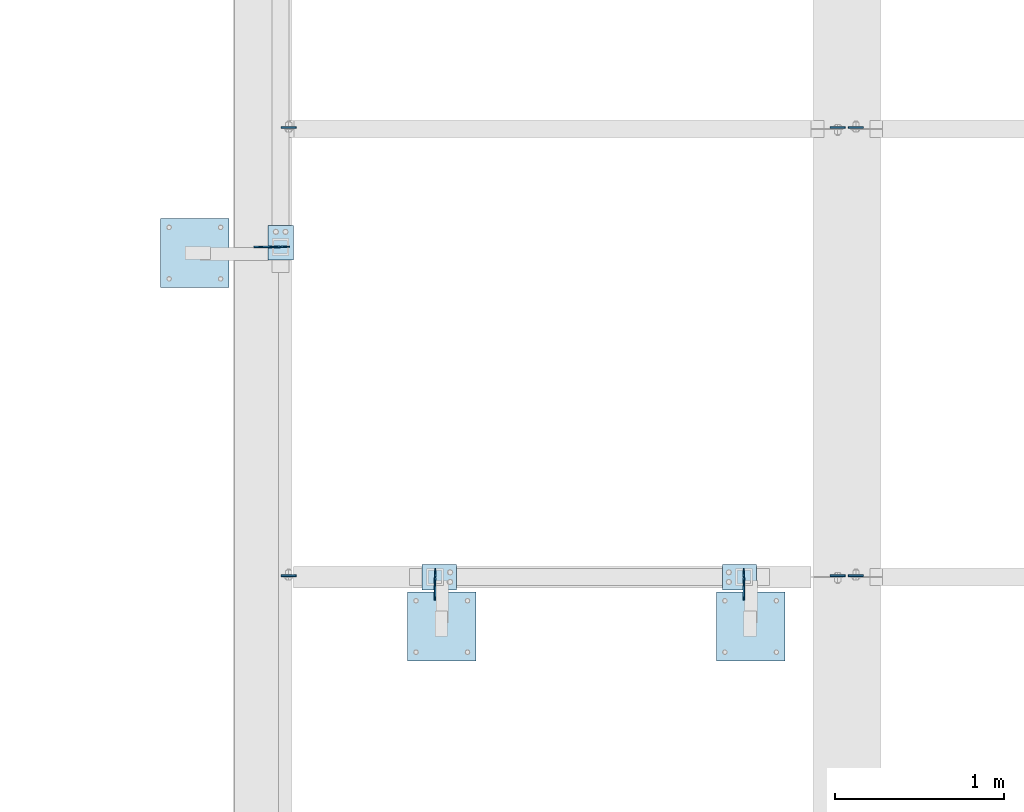
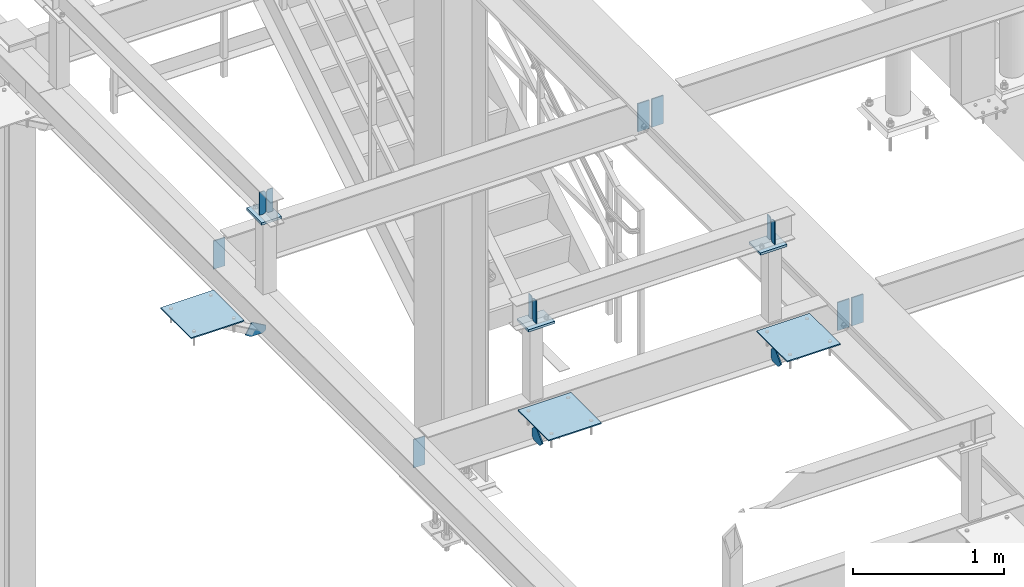
# One storey, part 3015 of 3843: 21 plates, 13 elements without a shape of their own.
"""IFC2X3 building model written with IfcOpenShell, lengths in millimetres."""

from ifc_helpers import new_model, si_unit, frame, origin_with_axes, place, context, subcontext, project, spatial, faceted_brep, material, type_object, element, aggregate, save


model = new_model("IFC2X3")

# Units and contexts
model_context = context("Model", 3, precision=1e-05, world=origin_with_axes())
body_context = subcontext(model_context, "Body", "Model", "MODEL_VIEW")
ifc_project = project(units=[si_unit("LENGTHUNIT", "METRE", prefix="MILLI"), si_unit("AREAUNIT", "SQUARE_METRE"), si_unit("VOLUMEUNIT", "CUBIC_METRE"), si_unit("MASSUNIT", "GRAM", prefix="KILO"), si_unit("TIMEUNIT", "SECOND"), si_unit("PLANEANGLEUNIT", "RADIAN"), si_unit("SOLIDANGLEUNIT", "STERADIAN"), si_unit("THERMODYNAMICTEMPERATUREUNIT", "DEGREE_CELSIUS"), si_unit("LUMINOUSINTENSITYUNIT", "LUMEN")], contexts=[model_context])

# Site, building, storey
site_placement = place(None, origin_with_axes())
site = spatial("IfcSite", under=ifc_project, at=site_placement, CompositionType="ELEMENT")
building_placement = place(site_placement, origin_with_axes())
building = spatial("IfcBuilding", under=site, at=building_placement, Name="Undefined", CompositionType="ELEMENT")
storey_placement = place(building_placement, origin_with_axes())
storey = spatial("IfcBuildingStorey", under=building, at=storey_placement, Name="Undefined", CompositionType="ELEMENT", Elevation=0.0)

# Assembly, plates
assembly_1_placement = place(storey_placement, origin_with_axes())
assembly_1 = element("IfcElementAssembly", 1, at=assembly_1_placement, inside=storey, Name="BEAM", AssemblyPlace="NOTDEFINED", PredefinedType="RIGID_FRAME")
ifc_material = material(Name="STEEL/A572-50")
plate_type_1 = type_object("IfcPlateType", PredefinedType="NOTDEFINED")
plate_1_placement = place(assembly_1_placement, frame((36585.525, 20315.2375, 34747.2), z_axis=(1.0, 0.0, 0.0), x_axis=(0.0, 0.0, -1.0)))
plate_1 = element("IfcPlate", 2, at=plate_1_placement, type_object=plate_type_1, material=ifc_material, Name="PLATE", context=body_context, shape_type="Brep", body=[
    faceted_brep([(0.0, -4.76249999999709, 0.0), (0.0, -4.76249999999709, 88.9000015258789), (0.0, 4.76249999999709, 88.9000015258789), (0.0, 4.76249999999709, 0.0), (228.600006102781, -4.7625000004191, 88.9000015257589), (228.600006102781, 4.76249999954598, 88.9000015257443), (228.600006103079, -4.7625000004482, 7.27595761418343e-12), (228.600006103079, 4.76249999954598, -7.27595761418343e-12)], [[[0, 1, 2, 3]], [[1, 4, 5, 2]], [[4, 6, 7, 5]], [[6, 0, 3, 7]], [[5, 7, 3, 2]], [[6, 4, 1, 0]]]),
])
plate_2_placement = place(assembly_1_placement, frame((36566.475, 20315.2375, 34747.2), z_axis=(-1.0, 0.0, 0.0), x_axis=(0.0, 0.0, -1.0)))
plate_2 = element("IfcPlate", 3, at=plate_2_placement, type_object=plate_type_1, material=ifc_material, Name="PLATE", context=body_context, shape_type="Brep", body=[
    faceted_brep([(0.0, -4.76249999999709, 0.0), (0.0, -4.76249999999709, 88.9000015258789), (0.0, 4.76249999999709, 88.9000015258789), (0.0, 4.76249999999709, 0.0), (228.600006102781, -4.7625000004191, 88.9000015257589), (228.600006102781, 4.76249999954598, 88.9000015257443), (228.600006103079, -4.7625000004482, 7.27595761418343e-12), (228.600006103079, 4.76249999954598, -7.27595761418343e-12)], [[[0, 1, 2, 3]], [[1, 4, 5, 2]], [[4, 6, 7, 5]], [[6, 0, 3, 7]], [[5, 7, 3, 2]], [[6, 4, 1, 0]]]),
])

# Assembly, plate
assembly_2_placement = place(storey_placement, origin_with_axes())
assembly_2 = element("IfcElementAssembly", 4, at=assembly_2_placement, inside=storey, Name="BEAM", AssemblyPlace="NOTDEFINED", PredefinedType="RIGID_FRAME")
plate_3_placement = place(assembly_2_placement, frame((33226.375, 20315.2375, 34772.6), z_axis=(1.0, 0.0, 0.0), x_axis=(0.0, 0.0, -1.0)))
plate_3 = element("IfcPlate", 5, at=plate_3_placement, type_object=plate_type_1, material=ifc_material, Name="PLATE", context=body_context, shape_type="Brep", body=[
    faceted_brep([(0.0, -4.76249999999709, 0.0), (0.0, -4.76249999999709, 88.9000015258789), (0.0, 4.76249999999709, 88.9000015258789), (0.0, 4.76249999999709, 0.0), (228.600006102781, -4.7625000004191, 88.9000015257589), (228.600006102781, 4.76249999954598, 88.9000015257443), (228.600006103079, -4.7625000004482, 7.27595761418343e-12), (228.600006103079, 4.76249999954598, -7.27595761418343e-12)], [[[0, 1, 2, 3]], [[1, 4, 5, 2]], [[4, 6, 7, 5]], [[6, 0, 3, 7]], [[5, 7, 3, 2]], [[6, 4, 1, 0]]]),
])

# Plate
plate_4_placement = place(assembly_1_placement, frame((36585.525, 22969.5375, 34747.2), z_axis=(1.0, 0.0, 0.0), x_axis=(0.0, 0.0, -1.0)))
plate_4 = element("IfcPlate", 6, at=plate_4_placement, type_object=plate_type_1, material=ifc_material, Name="PLATE", context=body_context, shape_type="Brep", body=[
    faceted_brep([(0.0, -4.76249999999709, 0.0), (0.0, -4.76249999999709, 88.9000015258789), (0.0, 4.76249999999709, 88.9000015258789), (0.0, 4.76249999999709, 0.0), (228.600006102781, -4.7625000004191, 88.9000015257589), (228.600006102781, 4.76249999954598, 88.9000015257443), (228.600006103079, -4.7625000004482, 7.27595761418343e-12), (228.600006103079, 4.76249999954598, -7.27595761418343e-12)], [[[0, 1, 2, 3]], [[1, 4, 5, 2]], [[4, 6, 7, 5]], [[6, 0, 3, 7]], [[5, 7, 3, 2]], [[6, 4, 1, 0]]]),
])

plate_5_placement = place(assembly_1_placement, frame((36566.475, 22969.5375, 34747.2), z_axis=(-1.0, 0.0, 0.0), x_axis=(0.0, 0.0, -1.0)))
plate_5 = element("IfcPlate", 7, at=plate_5_placement, type_object=plate_type_1, material=ifc_material, Name="PLATE", context=body_context, shape_type="Brep", body=[
    faceted_brep([(0.0, -4.76249999999709, 0.0), (0.0, -4.76249999999709, 88.9000015258789), (0.0, 4.76249999999709, 88.9000015258789), (0.0, 4.76249999999709, 0.0), (228.600006102781, -4.7625000004191, 88.9000015257589), (228.600006102781, 4.76249999954598, 88.9000015257443), (228.600006103079, -4.7625000004482, 7.27595761418343e-12), (228.600006103079, 4.76249999954598, -7.27595761418343e-12)], [[[0, 1, 2, 3]], [[1, 4, 5, 2]], [[4, 6, 7, 5]], [[6, 0, 3, 7]], [[5, 7, 3, 2]], [[6, 4, 1, 0]]]),
])

aggregate(assembly_1, [plate_1, plate_2, plate_4, plate_5])

plate_6_placement = place(assembly_2_placement, frame((33226.375, 22969.5375, 34772.6), z_axis=(1.0, 0.0, 0.0), x_axis=(0.0, 0.0, -1.0)))
plate_6 = element("IfcPlate", 8, at=plate_6_placement, type_object=plate_type_1, material=ifc_material, Name="PLATE", context=body_context, shape_type="Brep", body=[
    faceted_brep([(0.0, -4.76249999999709, 0.0), (0.0, -4.76249999999709, 88.9000015258789), (0.0, 4.76249999999709, 88.9000015258789), (0.0, 4.76249999999709, 0.0), (228.600006102781, -4.7625000004191, 88.9000015257589), (228.600006102781, 4.76249999954598, 88.9000015257443), (228.600006103079, -4.7625000004482, 7.27595761418343e-12), (228.600006103079, 4.76249999954598, -7.27595761418343e-12)], [[[0, 1, 2, 3]], [[1, 4, 5, 2]], [[4, 6, 7, 5]], [[6, 0, 3, 7]], [[5, 7, 3, 2]], [[6, 4, 1, 0]]]),
])

aggregate(assembly_2, [plate_3, plate_6])

# Assembly, plate
assembly_3_placement = place(storey_placement, origin_with_axes())
assembly_3 = element("IfcElementAssembly", 9, at=assembly_3_placement, inside=storey, Name="PLATE", AssemblyPlace="NOTDEFINED", PredefinedType="RIGID_FRAME")
plate_type_2 = type_object("IfcPlateType", PredefinedType="NOTDEFINED")
plate_7_placement = place(assembly_3_placement, frame((33220.0250000001, 22263.1, 34469.3875000009), z_axis=(-1.0, 0.0, 0.0), x_axis=(0.0, 0.0, 1.0)))
plate_7 = element("IfcPlate", 10, at=plate_7_placement, type_object=plate_type_2, material=ifc_material, Name="PLATE", context=body_context, shape_type="Brep", body=[
    faceted_brep([(0.0, -4.76249999999709, 19.0499992370605), (0.0, -4.76250000000073, 112.1731560966), (0.0, 4.76250000000073, 112.1731560966), (0.0, 4.76249999999709, 19.0499992370605), (25.4000000553569, -4.76250000000073, 156.167246576886), (25.4000000553569, 4.76250000000073, 156.167246576886), (113.388181015936, -4.76250000000073, 105.367246466165), (113.388181015936, 4.76250000000073, 105.367246466165), (52.5543727281402, -4.76250000000073, 0.0), (52.5543727281402, 4.76250000000073, 0.0), (19.0499992370605, -4.76249999999709, 0.0), (19.0499992370605, 4.76249999999709, 0.0)], [[[0, 1, 2, 3]], [[1, 4, 5, 2]], [[4, 6, 7, 5]], [[6, 8, 9, 7]], [[8, 10, 11, 9]], [[10, 0, 3, 11]], [[5, 7, 9, 11, 3, 2]], [[10, 8, 6, 4, 1, 0]]]),
])
aggregate(assembly_3, [plate_7])

# Assembly, plates
assembly_4_placement = place(storey_placement, origin_with_axes())
assembly_4 = element("IfcElementAssembly", 11, at=assembly_4_placement, inside=storey, Name="BEAM", AssemblyPlace="NOTDEFINED", PredefinedType="RIGID_FRAME")
plate_type_3 = type_object("IfcPlateType", PredefinedType="NOTDEFINED")
plate_8_placement = place(assembly_4_placement, frame((34137.6, 20256.5, 35615.5624969482), z_axis=(0.0, 0.0, -1.0), x_axis=(0.0, 1.0, 0.0)))
plate_8 = element("IfcPlate", 12, at=plate_8_placement, type_object=plate_type_3, material=ifc_material, Name="STIFFENER", context=body_context, shape_type="Brep", body=[
    faceted_brep([(0.0, -3.17499999999927, 0.0), (0.0, -3.17500000000291, 187.324999999997), (0.0, 3.17500000000291, 187.324999999997), (0.0, 3.17499999999927, 0.0), (34.9250001907349, -3.17500000000291, 187.324999999997), (34.9250001907349, 3.17500000000291, 187.324999999997), (47.625, -3.17500000000291, 174.625000190732), (47.625, 3.17500000000291, 174.625000190732), (47.625, -3.17499999999927, 12.6999998092651), (47.625, 3.17499999999927, 12.6999998092651), (34.9250001907349, -3.17499999999927, 0.0), (34.9250001907349, 3.17499999999927, 0.0)], [[[0, 1, 2, 3]], [[1, 4, 5, 2]], [[4, 6, 7, 5]], [[6, 8, 9, 7]], [[8, 10, 11, 9]], [[10, 0, 3, 11]], [[5, 7, 9, 11, 3, 2]], [[10, 8, 6, 4, 1, 0]]]),
])
plate_9_placement = place(assembly_4_placement, frame((34137.6, 20358.1, 35615.5624969482), z_axis=(0.0, 0.0, -1.0), x_axis=(0.0, -1.0, 0.0)))
plate_9 = element("IfcPlate", 13, at=plate_9_placement, type_object=plate_type_3, material=ifc_material, Name="STIFFENER", context=body_context, shape_type="Brep", body=[
    faceted_brep([(0.0, -3.17499999999927, 0.0), (0.0, -3.17500000000291, 187.324999999997), (0.0, 3.17500000000291, 187.324999999997), (0.0, 3.17499999999927, 0.0), (34.9250001907349, -3.17500000000291, 187.324999999997), (34.9250001907349, 3.17500000000291, 187.324999999997), (47.625, -3.17500000000291, 174.625000190732), (47.625, 3.17500000000291, 174.625000190732), (47.625, -3.17499999999927, 12.6999998092651), (47.625, 3.17499999999927, 12.6999998092651), (34.9250001907349, -3.17499999999927, 0.0), (34.9250001907349, 3.17499999999927, 0.0)], [[[0, 1, 2, 3]], [[1, 4, 5, 2]], [[4, 6, 7, 5]], [[6, 8, 9, 7]], [[8, 10, 11, 9]], [[10, 0, 3, 11]], [[5, 7, 9, 11, 3, 2]], [[10, 8, 6, 4, 1, 0]]]),
])
plate_10_placement = place(assembly_4_placement, frame((35966.4, 20358.1, 35615.5624969482), z_axis=(0.0, 0.0, -1.0), x_axis=(0.0, -1.0, 0.0)))
plate_10 = element("IfcPlate", 14, at=plate_10_placement, type_object=plate_type_3, material=ifc_material, Name="STIFFENER", context=body_context, shape_type="Brep", body=[
    faceted_brep([(0.0, -3.17499999999927, 0.0), (0.0, -3.17500000000291, 187.324999999997), (0.0, 3.17500000000291, 187.324999999997), (0.0, 3.17499999999927, 0.0), (34.9250001907349, -3.17500000000291, 187.324999999997), (34.9250001907349, 3.17500000000291, 187.324999999997), (47.625, -3.17500000000291, 174.625000190732), (47.625, 3.17500000000291, 174.625000190732), (47.625, -3.17499999999927, 12.6999998092651), (47.625, 3.17499999999927, 12.6999998092651), (34.9250001907349, -3.17499999999927, 0.0), (34.9250001907349, 3.17499999999927, 0.0)], [[[0, 1, 2, 3]], [[1, 4, 5, 2]], [[4, 6, 7, 5]], [[6, 8, 9, 7]], [[8, 10, 11, 9]], [[10, 0, 3, 11]], [[5, 7, 9, 11, 3, 2]], [[10, 8, 6, 4, 1, 0]]]),
])
plate_11_placement = place(assembly_4_placement, frame((35966.4, 20256.5, 35615.5624969482), z_axis=(0.0, 0.0, -1.0), x_axis=(0.0, 1.0, 0.0)))
plate_11 = element("IfcPlate", 15, at=plate_11_placement, type_object=plate_type_3, material=ifc_material, Name="STIFFENER", context=body_context, shape_type="Brep", body=[
    faceted_brep([(0.0, -3.17499999999927, 0.0), (0.0, -3.17500000000291, 187.324999999997), (0.0, 3.17500000000291, 187.324999999997), (0.0, 3.17499999999927, 0.0), (34.9250001907349, -3.17500000000291, 187.324999999997), (34.9250001907349, 3.17500000000291, 187.324999999997), (47.625, -3.17500000000291, 174.625000190732), (47.625, 3.17500000000291, 174.625000190732), (47.625, -3.17499999999927, 12.6999998092651), (47.625, 3.17499999999927, 12.6999998092651), (34.9250001907349, -3.17499999999927, 0.0), (34.9250001907349, 3.17499999999927, 0.0)], [[[0, 1, 2, 3]], [[1, 4, 5, 2]], [[4, 6, 7, 5]], [[6, 8, 9, 7]], [[8, 10, 11, 9]], [[10, 0, 3, 11]], [[5, 7, 9, 11, 3, 2]], [[10, 8, 6, 4, 1, 0]]]),
])
aggregate(assembly_4, [plate_8, plate_9, plate_10, plate_11])

assembly_5_placement = place(storey_placement, origin_with_axes())
assembly_5 = element("IfcElementAssembly", 16, at=assembly_5_placement, inside=storey, Name="BEAM", AssemblyPlace="NOTDEFINED", PredefinedType="RIGID_FRAME")
plate_12_placement = place(assembly_5_placement, frame((33274.0, 22263.1, 35615.5624969482), z_axis=(0.0, 0.0, -1.0), x_axis=(-1.0, 0.0, 0.0)))
plate_12 = element("IfcPlate", 17, at=plate_12_placement, type_object=plate_type_3, material=ifc_material, Name="STIFFENER", context=body_context, shape_type="Brep", body=[
    faceted_brep([(0.0, -3.17499999999927, 0.0), (0.0, -3.17500000000291, 187.324999999997), (0.0, 3.17500000000291, 187.324999999997), (0.0, 3.17499999999927, 0.0), (34.9250001907349, -3.17500000000291, 187.324999999997), (34.9250001907349, 3.17500000000291, 187.324999999997), (47.625, -3.17500000000291, 174.625000190732), (47.625, 3.17500000000291, 174.625000190732), (47.625, -3.17499999999927, 12.6999998092651), (47.625, 3.17499999999927, 12.6999998092651), (34.9250001907349, -3.17499999999927, 0.0), (34.9250001907349, 3.17499999999927, 0.0)], [[[0, 1, 2, 3]], [[1, 4, 5, 2]], [[4, 6, 7, 5]], [[6, 8, 9, 7]], [[8, 10, 11, 9]], [[10, 0, 3, 11]], [[5, 7, 9, 11, 3, 2]], [[10, 8, 6, 4, 1, 0]]]),
])
plate_13_placement = place(assembly_5_placement, frame((33172.4, 22263.1, 35615.5624969482), z_axis=(0.0, 0.0, -1.0), x_axis=(1.0, 0.0, 0.0)))
plate_13 = element("IfcPlate", 18, at=plate_13_placement, type_object=plate_type_3, material=ifc_material, Name="STIFFENER", context=body_context, shape_type="Brep", body=[
    faceted_brep([(0.0, -3.17499999999927, 0.0), (0.0, -3.17500000000291, 187.324999999997), (0.0, 3.17500000000291, 187.324999999997), (0.0, 3.17499999999927, 0.0), (34.9250001907349, -3.17500000000291, 187.324999999997), (34.9250001907349, 3.17500000000291, 187.324999999997), (47.625, -3.17500000000291, 174.625000190732), (47.625, 3.17500000000291, 174.625000190732), (47.625, -3.17499999999927, 12.6999998092651), (47.625, 3.17499999999927, 12.6999998092651), (34.9250001907349, -3.17499999999927, 0.0), (34.9250001907349, 3.17499999999927, 0.0)], [[[0, 1, 2, 3]], [[1, 4, 5, 2]], [[4, 6, 7, 5]], [[6, 8, 9, 7]], [[8, 10, 11, 9]], [[10, 0, 3, 11]], [[5, 7, 9, 11, 3, 2]], [[10, 8, 6, 4, 1, 0]]]),
])
aggregate(assembly_5, [plate_12, plate_13])

# Assembly, plate
assembly_6_placement = place(storey_placement, origin_with_axes())
assembly_6 = element("IfcElementAssembly", 19, at=assembly_6_placement, inside=storey, Name="PLATE", AssemblyPlace="NOTDEFINED", PredefinedType="RIGID_FRAME")
plate_type_4 = type_object("IfcPlateType", PredefinedType="NOTDEFINED")
plate_14_placement = place(assembly_6_placement, frame((34137.6, 20304.125, 34469.3875), z_axis=(0.0, -1.0, 0.0), x_axis=(0.0, 0.0, 1.0)))
plate_14 = element("IfcPlate", 20, at=plate_14_placement, type_object=plate_type_4, material=ifc_material, Name="PLATE", context=body_context, shape_type="Brep", body=[
    faceted_brep([(0.0, -4.76249999999709, 19.0499992370605), (0.0, -4.76249999999709, 94.5650612206882), (0.0, 4.76249999999709, 94.5650612206882), (0.0, 4.76249999999709, 19.0499992370605), (38.5980122320107, -4.76249999999709, 133.163073452699), (38.5980122320107, 4.76249999999709, 133.163073452699), (128.400573442581, -4.76249999999709, 43.3605122421359), (128.400573442581, 4.76249999999709, 43.3605122421359), (85.0400612004451, -4.76249999999709, 0.0), (85.0400612004451, 4.76249999999709, 0.0), (19.0499992370605, -4.76249999999709, 0.0), (19.0499992370605, 4.76249999999709, 0.0)], [[[0, 1, 2, 3]], [[1, 4, 5, 2]], [[4, 6, 7, 5]], [[6, 8, 9, 7]], [[8, 10, 11, 9]], [[10, 0, 3, 11]], [[5, 7, 9, 11, 3, 2]], [[10, 8, 6, 4, 1, 0]]]),
])
aggregate(assembly_6, [plate_14])

assembly_7_placement = place(storey_placement, origin_with_axes())
assembly_7 = element("IfcElementAssembly", 21, at=assembly_7_placement, inside=storey, Name="PLATE", AssemblyPlace="NOTDEFINED", PredefinedType="RIGID_FRAME")
plate_15_placement = place(assembly_7_placement, frame((35966.4, 20304.125, 34469.3875), z_axis=(0.0, -1.0, 0.0), x_axis=(0.0, 0.0, 1.0)))
plate_15 = element("IfcPlate", 22, at=plate_15_placement, type_object=plate_type_4, material=ifc_material, Name="PLATE", context=body_context, shape_type="Brep", body=[
    faceted_brep([(0.0, -4.76249999999709, 19.0499992370605), (0.0, -4.76249999999709, 94.5650612206882), (0.0, 4.76249999999709, 94.5650612206882), (0.0, 4.76249999999709, 19.0499992370605), (38.5980122320107, -4.76249999999709, 133.163073452699), (38.5980122320107, 4.76249999999709, 133.163073452699), (128.400573442581, -4.76249999999709, 43.3605122421359), (128.400573442581, 4.76249999999709, 43.3605122421359), (85.0400612004451, -4.76249999999709, 0.0), (85.0400612004451, 4.76249999999709, 0.0), (19.0499992370605, -4.76249999999709, 0.0), (19.0499992370605, 4.76249999999709, 0.0)], [[[0, 1, 2, 3]], [[1, 4, 5, 2]], [[4, 6, 7, 5]], [[6, 8, 9, 7]], [[8, 10, 11, 9]], [[10, 0, 3, 11]], [[5, 7, 9, 11, 3, 2]], [[10, 8, 6, 4, 1, 0]]]),
])
aggregate(assembly_7, [plate_15])

assembly_8_placement = place(storey_placement, origin_with_axes())
assembly_8 = element("IfcElementAssembly", 23, at=assembly_8_placement, inside=storey, Name="PLATE", AssemblyPlace="NOTDEFINED", PredefinedType="RIGID_FRAME")
plate_type_5 = type_object("IfcPlateType", PredefinedType="NOTDEFINED")
plate_16_placement = place(assembly_8_placement, frame((32918.399987793, 22429.7875, 34805.9375), z_axis=(0.0, -1.0, 0.0), x_axis=(-1.0, 0.0, 0.0)))
plate_16 = element("IfcPlate", 24, at=plate_16_placement, type_object=plate_type_5, material=ifc_material, Name="PLATE", context=body_context, shape_type="Brep", body=[
    faceted_brep([(0.0, -4.76249999999709, 0.0), (-7.27595761418343e-12, -4.76249999999709, 406.400000000009), (-7.27595761418343e-12, 4.76249999999709, 406.400000000009), (0.0, 4.76249999999709, 0.0), (406.399999999991, -4.76249999999709, 406.400000000009), (406.399999999991, 4.76249999999709, 406.400000000009), (406.399999999998, -4.76249999999709, 7.27595761418343e-12), (406.399999999998, 4.76249999999709, 7.27595761418343e-12)], [[[0, 1, 2, 3]], [[1, 4, 5, 2]], [[4, 6, 7, 5]], [[6, 0, 3, 7]], [[5, 7, 3, 2]], [[6, 4, 1, 0]]]),
])
aggregate(assembly_8, [plate_16])

assembly_9_placement = place(storey_placement, origin_with_axes())
assembly_9 = element("IfcElementAssembly", 25, at=assembly_9_placement, inside=storey, Name="PLATE", AssemblyPlace="NOTDEFINED", PredefinedType="RIGID_FRAME")
plate_17_placement = place(assembly_9_placement, frame((35802.8875, 20218.3065367162, 34805.9375), z_axis=(1.0, 0.0, 0.0), x_axis=(0.0, -1.0, 0.0)))
plate_17 = element("IfcPlate", 26, at=plate_17_placement, type_object=plate_type_5, material=ifc_material, Name="PLATE", context=body_context, shape_type="Brep", body=[
    faceted_brep([(0.0, -4.76249999999709, 0.0), (-7.27595761418343e-12, -4.76249999999709, 406.400000000009), (-7.27595761418343e-12, 4.76249999999709, 406.400000000009), (0.0, 4.76249999999709, 0.0), (406.399999999991, -4.76249999999709, 406.400000000009), (406.399999999991, 4.76249999999709, 406.400000000009), (406.399999999998, -4.76249999999709, 7.27595761418343e-12), (406.399999999998, 4.76249999999709, 7.27595761418343e-12)], [[[0, 1, 2, 3]], [[1, 4, 5, 2]], [[4, 6, 7, 5]], [[6, 0, 3, 7]], [[5, 7, 3, 2]], [[6, 4, 1, 0]]]),
])
aggregate(assembly_9, [plate_17])

assembly_10_placement = place(storey_placement, origin_with_axes())
assembly_10 = element("IfcElementAssembly", 27, at=assembly_10_placement, inside=storey, Name="PLATE", AssemblyPlace="NOTDEFINED", PredefinedType="RIGID_FRAME")
plate_18_placement = place(assembly_10_placement, frame((33974.0875, 20218.3065367162, 34805.9375), z_axis=(1.0, 0.0, 0.0), x_axis=(0.0, -1.0, 0.0)))
plate_18 = element("IfcPlate", 28, at=plate_18_placement, type_object=plate_type_5, material=ifc_material, Name="PLATE", context=body_context, shape_type="Brep", body=[
    faceted_brep([(0.0, -4.76249999999709, 0.0), (-7.27595761418343e-12, -4.76249999999709, 406.400000000009), (-7.27595761418343e-12, 4.76249999999709, 406.400000000009), (0.0, 4.76249999999709, 0.0), (406.399999999991, -4.76249999999709, 406.400000000009), (406.399999999991, 4.76249999999709, 406.400000000009), (406.399999999998, -4.76249999999709, 7.27595761418343e-12), (406.399999999998, 4.76249999999709, 7.27595761418343e-12)], [[[0, 1, 2, 3]], [[1, 4, 5, 2]], [[4, 6, 7, 5]], [[6, 0, 3, 7]], [[5, 7, 3, 2]], [[6, 4, 1, 0]]]),
])
aggregate(assembly_10, [plate_18])

assembly_11_placement = place(storey_placement, origin_with_axes())
assembly_11 = element("IfcElementAssembly", 29, at=assembly_11_placement, inside=storey, Name="POST", AssemblyPlace="NOTDEFINED", PredefinedType="RIGID_FRAME")
plate_type_6 = type_object("IfcPlateType", PredefinedType="NOTDEFINED")
plate_19_placement = place(assembly_11_placement, frame((34264.6, 20383.5, 35410.7749969482), z_axis=(-1.0, 0.0, 0.0), x_axis=(0.0, -1.0, 0.0)))
plate_19 = element("IfcPlate", 30, at=plate_19_placement, type_object=plate_type_6, material=ifc_material, Name="PLATE", context=body_context, shape_type="Brep", body=[
    faceted_brep([(0.0, -9.52500000000146, 0.0), (0.0, -9.52500000000146, 203.200000000004), (0.0, 9.52500000000146, 203.200000000004), (0.0, 9.52500000000146, 0.0), (152.400000000001, -9.52500000000146, 203.200000000004), (152.400000000001, 9.52500000000146, 203.200000000004), (152.400000000001, -9.52500000000146, 0.0), (152.400000000001, 9.52500000000146, 0.0)], [[[0, 1, 2, 3]], [[1, 4, 5, 2]], [[4, 6, 7, 5]], [[6, 0, 3, 7]], [[5, 7, 3, 2]], [[6, 4, 1, 0]]]),
])
aggregate(assembly_11, [plate_19])

assembly_12_placement = place(storey_placement, origin_with_axes())
assembly_12 = element("IfcElementAssembly", 31, at=assembly_12_placement, inside=storey, Name="POST", AssemblyPlace="NOTDEFINED", PredefinedType="RIGID_FRAME")
plate_20_placement = place(assembly_12_placement, frame((36042.6, 20383.5, 35410.7749969482), z_axis=(-1.0, 0.0, 0.0), x_axis=(0.0, -1.0, 0.0)))
plate_20 = element("IfcPlate", 32, at=plate_20_placement, type_object=plate_type_6, material=ifc_material, Name="PLATE", context=body_context, shape_type="Brep", body=[
    faceted_brep([(0.0, -9.52500000000146, 0.0), (0.0, -9.52500000000146, 203.200000000004), (0.0, 9.52500000000146, 203.200000000004), (0.0, 9.52500000000146, 0.0), (152.400000000001, -9.52500000000146, 203.200000000004), (152.400000000001, 9.52500000000146, 203.200000000004), (152.400000000001, -9.52500000000146, 0.0), (152.400000000001, 9.52500000000146, 0.0)], [[[0, 1, 2, 3]], [[1, 4, 5, 2]], [[4, 6, 7, 5]], [[6, 0, 3, 7]], [[5, 7, 3, 2]], [[6, 4, 1, 0]]]),
])
aggregate(assembly_12, [plate_20])

assembly_13_placement = place(storey_placement, origin_with_axes())
assembly_13 = element("IfcElementAssembly", 33, at=assembly_13_placement, inside=storey, Name="POST", AssemblyPlace="NOTDEFINED", PredefinedType="RIGID_FRAME")
plate_21_placement = place(assembly_13_placement, frame((33147.0, 22390.1, 35410.7749969482), z_axis=(0.0, -1.0, 0.0), x_axis=(1.0, 0.0, 0.0)))
plate_21 = element("IfcPlate", 34, at=plate_21_placement, type_object=plate_type_6, material=ifc_material, Name="PLATE", context=body_context, shape_type="Brep", body=[
    faceted_brep([(0.0, -9.52500000000146, 0.0), (0.0, -9.52500000000146, 203.200000000004), (0.0, 9.52500000000146, 203.200000000004), (0.0, 9.52500000000146, 0.0), (152.400000000001, -9.52500000000146, 203.200000000004), (152.400000000001, 9.52500000000146, 203.200000000004), (152.400000000001, -9.52500000000146, 0.0), (152.400000000001, 9.52500000000146, 0.0)], [[[0, 1, 2, 3]], [[1, 4, 5, 2]], [[4, 6, 7, 5]], [[6, 0, 3, 7]], [[5, 7, 3, 2]], [[6, 4, 1, 0]]]),
])
aggregate(assembly_13, [plate_21])

save(model, "model.ifc")
